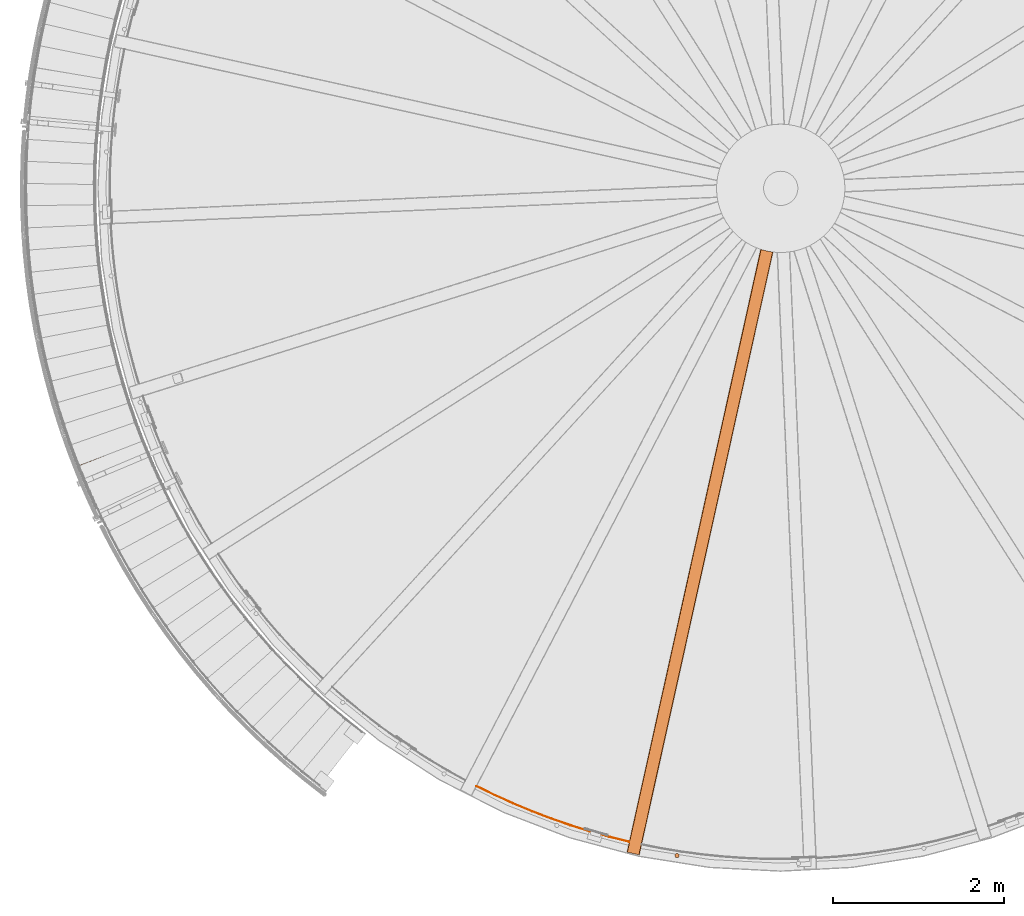
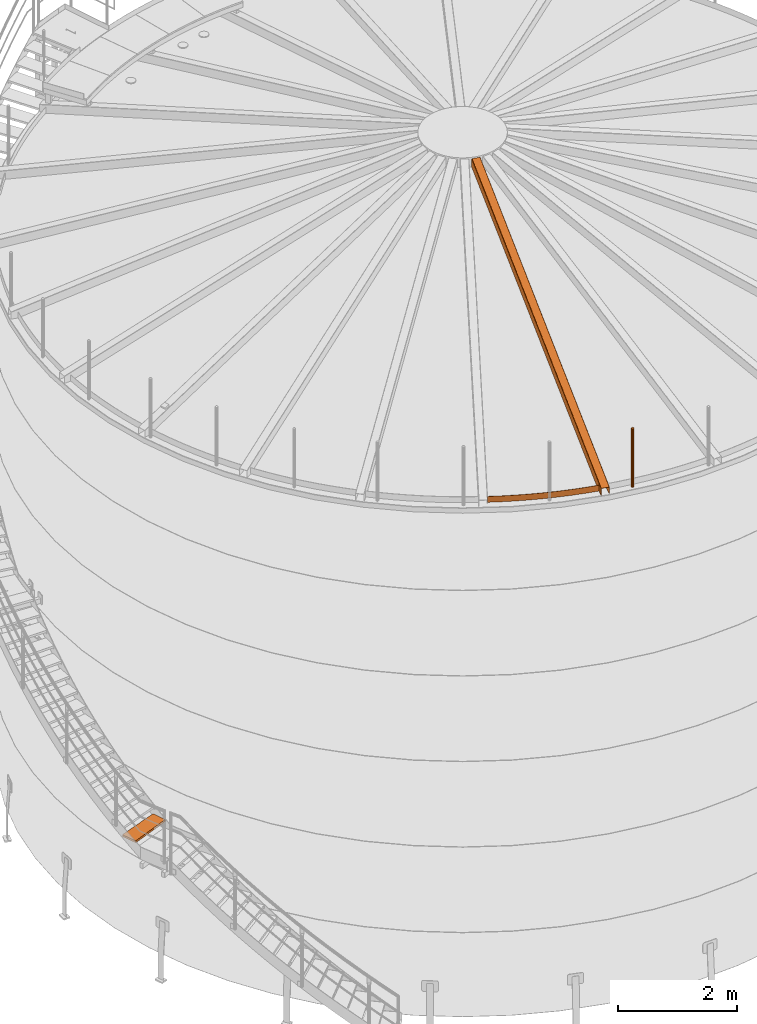
# One storey, part 8 of 126: 4 proxies.
"""IFC2X3 building model written with IfcOpenShell, lengths in millimetres."""

import ifcopenshell
import ifcopenshell.guid

model = None  # the IFC model being written
_history = None  # IfcOwnerHistory: only IFC2X3 demands one
_inside = {}  # id of a spatial element -> (the spatial element, [elements in it])
_under = {}  # id of a project, library or spatial element -> (it, [spatial elements below it])
_declared = {}  # id of a project -> (the project, [libraries it declares])
_typed = {}  # id of a type object -> (the type object, [elements of that type])
_made_of = {}  # id of a material, layer set ... -> (it, [elements and type objects made of it])


def new_model(schema):
    """Start an empty IFC model of exactly this schema.

    Asked for "IFC4X3", IfcOpenShell would pick the latest addendum, in which some entities
    have other attributes; the version numbers below select the first issue.
    IFC2X3 requires an IfcOwnerHistory on every rooted entity: one is made here for all.
    """
    global model, _history
    if schema == "IFC4X3":
        model = ifcopenshell.file(schema_version=(4, 3, 0, 0))
    else:
        model = ifcopenshell.file(schema=schema)
    _inside.clear()
    _under.clear()
    _declared.clear()
    _typed.clear()
    _made_of.clear()
    _history = None
    if model.schema == "IFC2X3":
        org = make("IfcOrganization", Name="unknown")
        user = make(
            "IfcPersonAndOrganization",
            ThePerson=make("IfcPerson", FamilyName="unknown"),
            TheOrganization=org,
        )
        app = make(
            "IfcApplication",
            ApplicationDeveloper=org,
            Version="unknown",
            ApplicationFullName="unknown",
            ApplicationIdentifier="unknown",
        )
        _history = make(
            "IfcOwnerHistory",
            OwningUser=user,
            OwningApplication=app,
            ChangeAction="ADDED",
            CreationDate=0,
        )
    return model


def make(cls, **values):
    """One entity of the class cls with the attributes given. An attribute that is None is left unset."""
    return model.create_entity(
        cls, **{name: value for name, value in values.items() if value is not None}
    )


def rooted(cls, **values):
    """An entity with a GlobalId (a new one), such as an element, a storey or a relation."""
    return make(cls, GlobalId=ifcopenshell.guid.new(), OwnerHistory=_history, **values)


def si_unit(unit_type, name, prefix=None):
    """IfcSIUnit, for example si_unit("LENGTHUNIT", "METRE", prefix="MILLI")."""
    return make("IfcSIUnit", UnitType=unit_type, Prefix=prefix, Name=name)


def assignment(units):
    """IfcUnitAssignment: the units of a project."""
    return None if units is None else make("IfcUnitAssignment", Units=units)


def point(xyz):
    """IfcCartesianPoint."""
    return None if xyz is None else make("IfcCartesianPoint", Coordinates=xyz)


def direction(xyz):
    """IfcDirection."""
    return None if xyz is None else make("IfcDirection", DirectionRatios=xyz)


def frame(location, z_axis=None, x_axis=None):
    """IfcAxis2Placement3D, a coordinate frame: its origin and axes. An axis left out is left unset."""
    return make(
        "IfcAxis2Placement3D",
        Location=point(location),
        Axis=direction(z_axis),
        RefDirection=direction(x_axis),
    )


def origin():
    """The frame at (0, 0, 0) with its axes left unset."""
    return frame((0.0, 0.0, 0.0))


def origin_with_axes():
    """The frame at (0, 0, 0) with the z axis (0, 0, 1) and the x axis (1, 0, 0) written out."""
    return frame((0.0, 0.0, 0.0), z_axis=(0.0, 0.0, 1.0), x_axis=(1.0, 0.0, 0.0))


def place(relative_to, where):
    """IfcLocalPlacement: puts the frame where relative to a parent placement (None: the world)."""
    return make(
        "IfcLocalPlacement", PlacementRelTo=relative_to, RelativePlacement=where
    )


def context(
    kind, dimensions, precision=None, world=None, true_north=None, identifier=None
):
    """IfcGeometricRepresentationContext, for example the 3D "Model" context."""
    return make(
        "IfcGeometricRepresentationContext",
        ContextIdentifier=identifier,
        ContextType=kind,
        CoordinateSpaceDimension=dimensions,
        Precision=precision,
        WorldCoordinateSystem=world,
        TrueNorth=true_north,
    )


def project(units=None, contexts=None):
    """IfcProject with its units and contexts."""
    return rooted(
        "IfcProject",
        Name="project",
        RepresentationContexts=contexts,
        UnitsInContext=assignment(units),
    )


def spatial(cls, under=None, at=None, **own):
    """A site, building, storey or space (cls), placed at a placement, below another one or the project."""
    s = rooted(cls, ObjectPlacement=at, **own)
    if under is not None:
        _under.setdefault(under.id(), (under, []))[1].append(s)
    return s


def faces_of(points, faces, orient=None, outer=None):
    """IfcFace entities. A face is a list of loops; a loop is a list of indices into points, from 0.

    orient and outer hold one flag for each loop. By default every Orientation is true, the
    first loop of a face is its IfcFaceOuterBound and the others are IfcFaceBound.
    """
    made = []
    for i, loops in enumerate(faces):
        bounds = []
        for j, loop in enumerate(loops):
            is_outer = j == 0 if outer is None else outer[i][j]
            bounds.append(
                make(
                    "IfcFaceOuterBound" if is_outer else "IfcFaceBound",
                    Bound=make("IfcPolyLoop", Polygon=[points[k] for k in loop]),
                    Orientation=True if orient is None else orient[i][j],
                )
            )
        made.append(make("IfcFace", Bounds=bounds))
    return made


def faceted_brep(points, faces, orient=None, outer=None, voids=None):
    """IfcFacetedBrep: a solid bounded by flat faces; with voids (closed shells), ...WithVoids."""
    shared = [point(p) for p in points]
    hull = make("IfcClosedShell", CfsFaces=faces_of(shared, faces, orient, outer))
    if voids is None:
        return make("IfcFacetedBrep", Outer=hull)
    return make(
        "IfcFacetedBrepWithVoids",
        Outer=hull,
        Voids=[
            make(cls, CfsFaces=faces_of(shared, fs, o, b)) for cls, fs, o, b in voids
        ],
    )


def shape(context_of_items, identifier, shape_type, items):
    """IfcShapeRepresentation: the items that make up one representation, for example the "Body"."""
    return make(
        "IfcShapeRepresentation",
        ContextOfItems=context_of_items,
        RepresentationIdentifier=identifier,
        RepresentationType=shape_type,
        Items=items,
    )


def material(Name=None, Category=None):
    """IfcMaterial."""
    return make("IfcMaterial", Name=Name, Category=Category)


def made_of(thing, what):
    """Note that an element or type object is made of a material, layer set ...; save() writes the relation."""
    if what is not None:
        _made_of.setdefault(what.id(), (what, []))[1].append(thing)
    return thing


def element(
    cls,
    number,
    at=None,
    inside=None,
    cuts=None,
    type_object=None,
    material=None,
    context=None,
    identifier="Body",
    shape_type=None,
    held_by="IfcProductDefinitionShape",
    body=None,
    shapes=None,
    **own,
):
    """One element of the class cls, such as IfcWall. Its Tag is "e" and its number.

    at: its placement. inside: the storey or other place that contains it. cuts: it is an
    opening in that element (IfcRelVoidsElement). A single representation is given by context,
    identifier, shape_type and body (its items); several are given by shapes. held_by: the class
    of the entity that holds the representations. save() writes the other relations.
    """
    e = rooted(cls, Tag="e%d" % number, ObjectPlacement=at, **own)
    if body is not None:
        shapes = [shape(context, identifier, shape_type, body)]
    if shapes is not None:
        e.Representation = make(held_by, Representations=shapes)
    if inside is not None:
        _inside.setdefault(inside.id(), (inside, []))[1].append(e)
    if cuts is not None:
        rooted(
            "IfcRelVoidsElement", RelatingBuildingElement=cuts, RelatedOpeningElement=e
        )
    if type_object is not None:
        _typed.setdefault(type_object.id(), (type_object, []))[1].append(e)
    return made_of(e, material)


def aggregate(whole, parts):
    """IfcRelAggregates: a whole, such as a stair, and the parts it consists of."""
    return rooted("IfcRelAggregates", RelatingObject=whole, RelatedObjects=parts)


def save(model, path):
    """Write the relations noted so far, then the file.

    IfcRelAggregates (storeys below a building ...), IfcRelContainedInSpatialStructure (elements
    in a storey), IfcRelDefinesByType, IfcRelAssociatesMaterial and IfcRelDeclares: one each for
    every whole, place, type object, material and project.
    """
    for whole, parts in _under.values():
        aggregate(whole, parts)
    for where, things in _inside.values():
        rooted(
            "IfcRelContainedInSpatialStructure",
            RelatedElements=things,
            RelatingStructure=where,
        )
    for kind, things in _typed.values():
        rooted("IfcRelDefinesByType", RelatedObjects=things, RelatingType=kind)
    for what, things in _made_of.values():
        rooted("IfcRelAssociatesMaterial", RelatedObjects=things, RelatingMaterial=what)
    for by, libraries in _declared.values():
        rooted("IfcRelDeclares", RelatingContext=by, RelatedDefinitions=libraries)
    model.write(path)


model = new_model("IFC2X3")

# Units and contexts
context_of_model_1 = context(None, 3, precision=0.1, world=origin())
context_of_model_2 = context(None, 3, precision=0.1, world=origin())
ifc_project = project(units=[si_unit("LENGTHUNIT", "METRE", prefix="MILLI"), si_unit("AREAUNIT", "SQUARE_METRE", prefix="CENTI"), si_unit("VOLUMEUNIT", "CUBIC_METRE", prefix="CENTI"), si_unit("MASSUNIT", "GRAM", prefix="KILO")], contexts=[context_of_model_1, context_of_model_2])

# Site, building, storey
site_placement = place(None, origin_with_axes())
site = spatial("IfcSite", under=ifc_project, at=site_placement, CompositionType="ELEMENT")
building_placement = place(site_placement, origin_with_axes())
building = spatial("IfcBuilding", under=site, at=building_placement, CompositionType="ELEMENT")
storey_placement = place(building_placement, origin_with_axes())
storey = spatial("IfcBuildingStorey", under=building, at=storey_placement, CompositionType="ELEMENT")

# Proxies
ifc_material_1 = material(Name="HOLZ")
proxy_1_placement = place(storey_placement, origin_with_axes())
element("IfcBuildingElementProxy", 1, at=proxy_1_placement, inside=storey, material=ifc_material_1, context=context_of_model_2, shape_type="Brep", body=[
    faceted_brep([(-296.0296, 5033.0652, 2944.5062), (-287.1199, 5008.2958, 2944.5062), (-278.1363, 4983.5532, 2944.5062), (-269.079, 4958.8375, 2944.5062), (-259.9478, 4934.1489, 2944.5062), (-250.743, 4909.4877, 2944.5062), (-241.4646, 4884.8541, 2944.5062), (-232.1127, 4860.2484, 2944.5062), (-222.6874, 4835.6706, 2944.5062), (-213.1888, 4811.1211, 2944.5062), (-203.6169, 4786.6001, 2944.5062), (-193.9718, 4762.1077, 2944.5062), (549.9522, 5056.3476, 2944.5062), (540.2096, 5081.0995, 2944.5062), (530.5493, 5105.8837, 2944.5062), (520.9712, 5130.6998, 2944.5062), (511.4755, 5155.5475, 2944.5062), (502.0623, 5180.4266, 2944.5062), (492.7317, 5205.3368, 2944.5062), (483.4839, 5230.2778, 2944.5062), (474.3188, 5255.2493, 2944.5062), (465.2366, 5280.2511, 2944.5062), (456.2374, 5305.2829, 2944.5062), (-296.0296, 5033.0652, 2904.5062), (456.2374, 5305.2829, 2904.5062), (465.2366, 5280.2511, 2904.5062), (474.3188, 5255.2493, 2904.5062), (483.4839, 5230.2778, 2904.5062), (492.7317, 5205.3368, 2904.5062), (502.0623, 5180.4266, 2904.5062), (511.4755, 5155.5475, 2904.5062), (520.9712, 5130.6998, 2904.5062), (530.5493, 5105.8837, 2904.5062), (540.2096, 5081.0995, 2904.5062), (549.9522, 5056.3476, 2904.5062), (-193.9718, 4762.1077, 2904.5062), (-203.6169, 4786.6001, 2904.5062), (-213.1888, 4811.1211, 2904.5062), (-222.6874, 4835.6706, 2904.5062), (-232.1127, 4860.2484, 2904.5062), (-241.4646, 4884.8541, 2904.5062), (-250.743, 4909.4877, 2904.5062), (-259.9478, 4934.1489, 2904.5062), (-269.079, 4958.8375, 2904.5062), (-278.1363, 4983.5532, 2904.5062), (-287.1199, 5008.2958, 2904.5062)], [[[0, 1, 2, 3, 4, 5, 6, 7, 8, 9, 10, 11, 12, 13, 14, 15, 16, 17, 18, 19, 20, 21, 22]], [[23, 24, 25, 26, 27, 28, 29, 30, 31, 32, 33, 34, 35, 36, 37, 38, 39, 40, 41, 42, 43, 44, 45]], [[0, 23, 45, 1]], [[1, 45, 44, 2]], [[2, 44, 43, 3]], [[3, 43, 42, 4]], [[4, 42, 41, 5]], [[5, 41, 40, 6]], [[6, 40, 39, 7]], [[7, 39, 38, 8]], [[8, 38, 37, 9]], [[9, 37, 36, 10]], [[10, 36, 35, 11]], [[11, 35, 34, 12]], [[12, 34, 33, 13]], [[13, 33, 32, 14]], [[14, 32, 31, 15]], [[15, 31, 30, 16]], [[16, 30, 29, 17]], [[17, 29, 28, 18]], [[18, 28, 27, 19]], [[19, 27, 26, 20]], [[20, 26, 25, 21]], [[21, 25, 24, 22]], [[22, 24, 23, 0]]]),
])
ifc_material_2 = material(Name="STAHL")
proxy_2_placement = place(storey_placement, origin_with_axes())
element("IfcBuildingElementProxy", 2, at=proxy_2_placement, inside=storey, material=ifc_material_2, Name="profile", context=context_of_model_2, shape_type="Brep", body=[
    faceted_brep([(6779.2, 228.0, 11706.0), (6779.2, 228.0, 10506.0), (6774.9, 224.0, 10506.0), (6774.9, 224.0, 11706.0), (6771.8, 219.1, 10506.0), (6771.8, 219.1, 11706.0), (6769.9, 213.6, 10506.0), (6769.9, 213.6, 11706.0), (6769.4, 207.8, 10506.0), (6769.4, 207.8, 11706.0), (6770.2, 202.1, 10506.0), (6770.2, 202.1, 11706.0), (6772.5, 196.7, 10506.0), (6772.5, 196.7, 11706.0), (6775.9, 192.0, 10506.0), (6775.9, 192.0, 11706.0), (6780.4, 188.3, 10506.0), (6780.4, 188.3, 11706.0), (6785.6, 185.7, 10506.0), (6785.6, 185.7, 11706.0), (6791.3, 184.5, 10506.0), (6791.3, 184.5, 11706.0), (6797.1, 184.7, 10506.0), (6797.1, 184.7, 11706.0), (6802.8, 186.3, 10506.0), (6802.8, 186.3, 11706.0), (6807.8, 189.1, 10506.0), (6807.8, 189.1, 11706.0), (6812.1, 193.1, 11706.0), (6812.1, 193.1, 10506.0), (6815.2, 198.0, 11706.0), (6815.2, 198.0, 10506.0), (6817.1, 203.5, 11706.0), (6817.1, 203.5, 10506.0), (6817.6, 209.3, 11706.0), (6817.6, 209.3, 10506.0), (6816.8, 215.1, 11706.0), (6816.8, 215.1, 10506.0), (6814.5, 220.4, 11706.0), (6814.5, 220.4, 10506.0), (6811.1, 225.1, 11706.0), (6811.1, 225.1, 10506.0), (6806.6, 228.9, 11706.0), (6806.6, 228.9, 10506.0), (6801.4, 231.4, 11706.0), (6801.4, 231.4, 10506.0), (6795.7, 232.6, 11706.0), (6795.7, 232.6, 10506.0), (6789.8, 232.4, 11706.0), (6789.8, 232.4, 10506.0), (6784.2, 230.9, 11706.0), (6784.2, 230.9, 10506.0)], [[[0, 1, 2, 3]], [[3, 2, 4, 5]], [[5, 4, 6, 7]], [[7, 6, 8, 9]], [[9, 8, 10, 11]], [[11, 10, 12, 13]], [[13, 12, 14, 15]], [[15, 14, 16, 17]], [[17, 16, 18, 19]], [[19, 18, 20, 21]], [[21, 20, 22, 23]], [[23, 22, 24, 25]], [[25, 24, 26, 27]], [[28, 27, 26, 29]], [[30, 28, 29, 31]], [[32, 30, 31, 33]], [[34, 32, 33, 35]], [[36, 34, 35, 37]], [[38, 36, 37, 39]], [[40, 38, 39, 41]], [[42, 40, 41, 43]], [[44, 42, 43, 45]], [[46, 44, 45, 47]], [[48, 46, 47, 49]], [[50, 48, 49, 51]], [[0, 50, 51, 1]], [[21, 23, 25, 27, 28, 30, 32, 34, 36, 38, 40, 42, 44, 46, 48, 50, 0, 3, 5, 7, 9, 11, 13, 15, 17, 19]], [[20, 18, 16, 14, 12, 10, 8, 6, 4, 2, 1, 51, 49, 47, 45, 43, 41, 39, 37, 35, 33, 31, 29, 26, 24, 22]]]),
])
proxy_3_placement = place(storey_placement, origin_with_axes())
element("IfcBuildingElementProxy", 3, at=proxy_3_placement, inside=storey, material=ifc_material_2, Name="profile", context=context_of_model_2, shape_type="Brep", body=[
    faceted_brep([(7915.7, 7260.3, 12406.2), (7911.7, 7260.8, 12406.1), (7911.7, 7260.8, 12573.8), (7911.7, 7260.8, 12574.5), (7911.5, 7260.9, 12575.2), (7911.1, 7260.9, 12576.0), (7910.7, 7261.0, 12576.6), (7910.1, 7261.0, 12577.1), (7909.5, 7261.1, 12577.5), (7908.7, 7261.2, 12577.8), (7907.7, 7261.3, 12577.9), (7842.7, 7272.8, 12577.1), (7777.0, 7290.5, 12577.9), (7776.5, 7290.6, 12577.9), (7776.1, 7290.8, 12577.8), (7775.3, 7291.0, 12577.6), (7774.6, 7291.3, 12577.1), (7774.0, 7291.4, 12576.5), (7773.6, 7291.6, 12575.8), (7773.3, 7291.7, 12574.9), (7773.1, 7291.7, 12573.9), (7773.1, 7291.7, 12406.2), (7769.3, 7293.0, 12406.3), (7769.3, 7293.0, 12574.0), (7769.4, 7293.0, 12575.4), (7769.8, 7292.8, 12576.8), (7770.4, 7292.6, 12578.2), (7771.3, 7292.3, 12579.5), (7772.3, 7292.0, 12580.5), (7773.6, 7291.6, 12581.3), (7775.2, 7291.1, 12581.9), (7777.0, 7290.5, 12582.1), (7842.7, 7272.8, 12581.2), (7907.7, 7261.3, 12582.0), (7908.6, 7261.2, 12582.0), (7909.5, 7261.1, 12581.8), (7911.1, 7260.9, 12581.3), (7912.6, 7260.7, 12580.4), (7913.8, 7260.6, 12579.2), (7914.8, 7260.4, 12577.8), (7915.5, 7260.4, 12576.0), (7915.7, 7260.3, 12573.9), (6354.2, 217.7, 10642.6), (6353.8, 217.8, 10644.2), (6352.9, 218.0, 10645.9), (6351.6, 218.3, 10647.3), (6350.1, 218.6, 10648.4), (6348.4, 219.0, 10649.1), (6346.6, 219.4, 10649.3), (6215.8, 248.4, 10649.3), (6214.2, 248.7, 10649.2), (6212.8, 249.1, 10648.7), (6211.2, 249.4, 10647.7), (6209.8, 249.7, 10646.4), (6208.8, 249.9, 10644.8), (6208.2, 250.1, 10643.0), (6207.9, 250.1, 10641.0), (6207.9, 250.1, 10506.0), (6211.8, 249.3, 10506.0), (6211.8, 249.3, 10641.0), (6211.9, 249.3, 10641.8), (6212.1, 249.2, 10642.6), (6212.6, 249.1, 10643.5), (6213.2, 249.0, 10644.2), (6214.0, 248.8, 10644.7), (6214.8, 248.6, 10645.1), (6215.8, 248.4, 10645.2), (6346.6, 219.4, 10645.2), (6347.3, 219.2, 10645.1), (6348.1, 219.1, 10644.9), (6348.9, 218.9, 10644.4), (6349.5, 218.7, 10643.7), (6350.1, 218.6, 10642.9), (6350.4, 218.6, 10642.0), (6350.5, 218.5, 10641.0), (6350.5, 218.5, 10506.0), (6354.4, 217.7, 10506.0), (6354.4, 217.7, 10641.0), (6238.2, 368.4, 10506.0), (6234.3, 369.2, 10506.0), (6380.8, 336.8, 10506.0), (6376.9, 337.6, 10506.0)], [[[0, 1, 2, 3, 4, 5, 6, 7, 8, 9, 10, 11, 12, 13, 14, 15, 16, 17, 18, 19, 20, 21, 22, 23, 24, 25, 26, 27, 28, 29, 30, 31, 32, 33, 34, 35, 36, 37, 38, 39, 40, 41]], [[42, 43, 44, 45, 46, 47, 48, 49, 50, 51, 52, 53, 54, 55, 56, 57, 58, 59, 60, 61, 62, 63, 64, 65, 66, 67, 68, 69, 70, 71, 72, 73, 74, 75, 76, 77]], [[21, 78, 79, 22]], [[57, 56, 55, 24, 23, 22, 79]], [[54, 26, 25, 24, 55]], [[26, 54, 53, 27]], [[27, 53, 52, 28]], [[29, 28, 52, 51]], [[30, 29, 51, 50]], [[47, 35, 34, 33, 32, 31, 30, 50, 49, 48]], [[36, 35, 47, 46]], [[37, 36, 46, 45]], [[38, 37, 45, 44]], [[39, 38, 44, 43]], [[40, 39, 43, 42]], [[42, 77, 76, 80, 0, 41, 40]], [[1, 0, 80, 81]], [[75, 81, 80, 76]], [[58, 57, 79, 78]], [[59, 58, 78, 21, 20, 19, 60]], [[19, 18, 61, 60]], [[18, 17, 62, 61]], [[17, 16, 63, 62]], [[16, 15, 64, 63]], [[15, 14, 65, 64]], [[68, 67, 66, 65, 14, 13, 12, 11, 10, 9]], [[9, 8, 69, 68]], [[8, 7, 70, 69]], [[6, 71, 70, 7]], [[5, 72, 71, 6]], [[72, 5, 4, 3, 73]], [[75, 74, 73, 3, 2, 1, 81]]]),
])
proxy_4_placement = place(storey_placement, origin_with_axes())
element("IfcBuildingElementProxy", 4, at=proxy_4_placement, inside=storey, material=ifc_material_2, Name="profile", context=context_of_model_2, shape_type="Brep", body=[
    faceted_brep([(6234.5, 367.7, 10516.0), (6234.5, 367.7, 10636.0), (6003.6, 424.9, 10636.0), (5774.5, 489.1, 10636.0), (5547.4, 560.3, 10636.0), (5322.7, 638.3, 10636.0), (5100.4, 723.1, 10636.0), (4880.8, 814.6, 10636.0), (4664.0, 912.7, 10636.0), (4450.3, 1017.3, 10636.0), (4450.3, 1017.3, 10516.0), (4664.0, 912.7, 10516.0), (4880.8, 814.6, 10516.0), (5100.4, 723.1, 10516.0), (5322.7, 638.3, 10516.0), (5547.4, 560.3, 10516.0), (5774.5, 489.1, 10516.0), (6003.6, 424.9, 10516.0), (6235.6, 372.6, 10636.0), (6004.8, 429.8, 10636.0), (5775.9, 493.9, 10636.0), (5549.0, 565.0, 10636.0), (5324.4, 643.0, 10636.0), (5102.2, 727.7, 10636.0), (4882.7, 819.1, 10636.0), (4666.1, 917.2, 10636.0), (4452.6, 1021.8, 10636.0), (6235.6, 372.6, 10516.0), (6004.8, 429.8, 10516.0), (5775.9, 493.9, 10516.0), (5549.0, 565.0, 10516.0), (5324.4, 643.0, 10516.0), (5102.2, 727.7, 10516.0), (4882.7, 819.1, 10516.0), (4666.1, 917.2, 10516.0), (4452.6, 1021.8, 10516.0)], [[[0, 1, 2, 3, 4, 5, 6, 7, 8, 9, 10, 11, 12, 13, 14, 15, 16, 17]], [[1, 18, 19, 20, 21, 22, 23, 24, 25, 26, 9, 8, 7, 6, 5, 4, 3, 2]], [[18, 27, 28, 29, 30, 31, 32, 33, 34, 35, 26, 25, 24, 23, 22, 21, 20, 19]], [[0, 17, 16, 15, 14, 13, 12, 11, 10, 35, 34, 33, 32, 31, 30, 29, 28, 27]], [[18, 1, 0, 27]], [[9, 26, 35, 10]]]),
])

save(model, "model.ifc")
